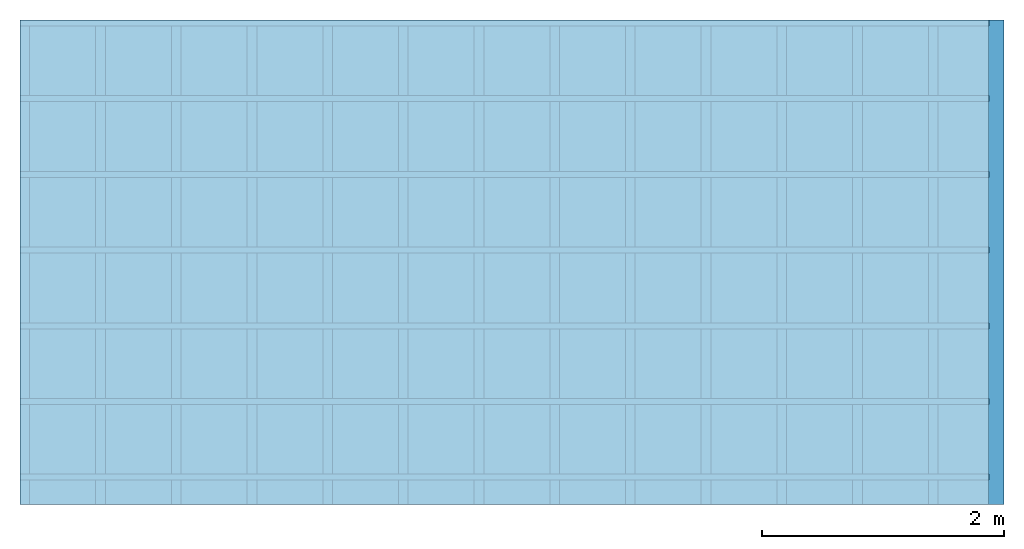
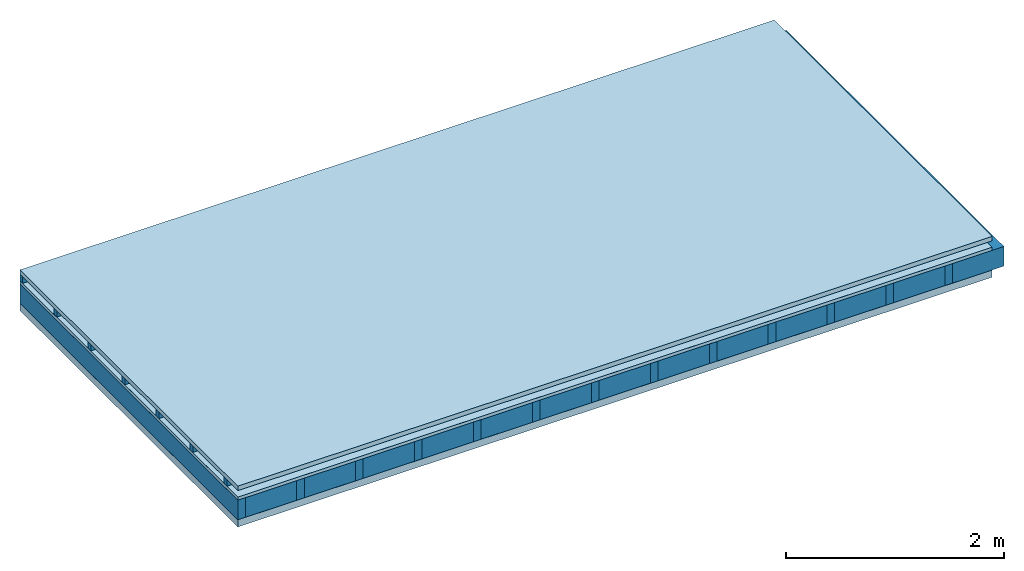
# One storey: 5 plates, 3 members, 1 element without a shape of its own.
"""IFC4 building model written with IfcOpenShell, lengths in metres."""

import ifcopenshell
import ifcopenshell.guid

model = None  # the IFC model being written
_history = None  # IfcOwnerHistory: only IFC2X3 demands one
_inside = {}  # id of a spatial element -> (the spatial element, [elements in it])
_under = {}  # id of a project, library or spatial element -> (it, [spatial elements below it])
_declared = {}  # id of a project -> (the project, [libraries it declares])
_typed = {}  # id of a type object -> (the type object, [elements of that type])
_made_of = {}  # id of a material, layer set ... -> (it, [elements and type objects made of it])


def new_model(schema):
    """Start an empty IFC model of exactly this schema.

    Asked for "IFC4X3", IfcOpenShell would pick the latest addendum, in which some entities
    have other attributes; the version numbers below select the first issue.
    IFC2X3 requires an IfcOwnerHistory on every rooted entity: one is made here for all.
    """
    global model, _history
    if schema == "IFC4X3":
        model = ifcopenshell.file(schema_version=(4, 3, 0, 0))
    else:
        model = ifcopenshell.file(schema=schema)
    _inside.clear()
    _under.clear()
    _declared.clear()
    _typed.clear()
    _made_of.clear()
    _history = None
    if model.schema == "IFC2X3":
        org = make("IfcOrganization", Name="unknown")
        user = make(
            "IfcPersonAndOrganization",
            ThePerson=make("IfcPerson", FamilyName="unknown"),
            TheOrganization=org,
        )
        app = make(
            "IfcApplication",
            ApplicationDeveloper=org,
            Version="unknown",
            ApplicationFullName="unknown",
            ApplicationIdentifier="unknown",
        )
        _history = make(
            "IfcOwnerHistory",
            OwningUser=user,
            OwningApplication=app,
            ChangeAction="ADDED",
            CreationDate=0,
        )
    return model


def make(cls, **values):
    """One entity of the class cls with the attributes given. An attribute that is None is left unset."""
    return model.create_entity(
        cls, **{name: value for name, value in values.items() if value is not None}
    )


def rooted(cls, **values):
    """An entity with a GlobalId (a new one), such as an element, a storey or a relation."""
    return make(cls, GlobalId=ifcopenshell.guid.new(), OwnerHistory=_history, **values)


def si_unit(unit_type, name, prefix=None):
    """IfcSIUnit, for example si_unit("LENGTHUNIT", "METRE", prefix="MILLI")."""
    return make("IfcSIUnit", UnitType=unit_type, Prefix=prefix, Name=name)


def derived_unit(unit_type, elements):
    """IfcDerivedUnit: a product of units, each with its exponent."""
    return make(
        "IfcDerivedUnit",
        Elements=[
            make("IfcDerivedUnitElement", Unit=unit, Exponent=power)
            for unit, power in elements
        ],
        UnitType=unit_type,
    )


def assignment(units):
    """IfcUnitAssignment: the units of a project."""
    return None if units is None else make("IfcUnitAssignment", Units=units)


def point(xyz):
    """IfcCartesianPoint."""
    return None if xyz is None else make("IfcCartesianPoint", Coordinates=xyz)


def direction(xyz):
    """IfcDirection."""
    return None if xyz is None else make("IfcDirection", DirectionRatios=xyz)


def frame(location, z_axis=None, x_axis=None):
    """IfcAxis2Placement3D, a coordinate frame: its origin and axes. An axis left out is left unset."""
    return make(
        "IfcAxis2Placement3D",
        Location=point(location),
        Axis=direction(z_axis),
        RefDirection=direction(x_axis),
    )


def frame_2d(location, x_axis=None):
    """IfcAxis2Placement2D, a coordinate frame in the plane: its origin and x axis."""
    return make(
        "IfcAxis2Placement2D", Location=point(location), RefDirection=direction(x_axis)
    )


def origin():
    """The frame at (0, 0, 0) with its axes left unset."""
    return frame((0.0, 0.0, 0.0))


def origin_with_axes():
    """The frame at (0, 0, 0) with the z axis (0, 0, 1) and the x axis (1, 0, 0) written out."""
    return frame((0.0, 0.0, 0.0), z_axis=(0.0, 0.0, 1.0), x_axis=(1.0, 0.0, 0.0))


def place(relative_to, where):
    """IfcLocalPlacement: puts the frame where relative to a parent placement (None: the world)."""
    return make(
        "IfcLocalPlacement", PlacementRelTo=relative_to, RelativePlacement=where
    )


def context(
    kind, dimensions, precision=None, world=None, true_north=None, identifier=None
):
    """IfcGeometricRepresentationContext, for example the 3D "Model" context."""
    return make(
        "IfcGeometricRepresentationContext",
        ContextIdentifier=identifier,
        ContextType=kind,
        CoordinateSpaceDimension=dimensions,
        Precision=precision,
        WorldCoordinateSystem=world,
        TrueNorth=true_north,
    )


def project(units=None, contexts=None):
    """IfcProject with its units and contexts."""
    return rooted(
        "IfcProject",
        Name="project",
        RepresentationContexts=contexts,
        UnitsInContext=assignment(units),
    )


def spatial(cls, under=None, at=None, **own):
    """A site, building, storey or space (cls), placed at a placement, below another one or the project."""
    s = rooted(cls, ObjectPlacement=at, **own)
    if under is not None:
        _under.setdefault(under.id(), (under, []))[1].append(s)
    return s


def profile(cls, at=None, kind="AREA", **sizes):
    """A parametric profile (cls). Its sizes go by their IFC names, for example OverallWidth=200.0."""
    return make(cls, ProfileType=kind, Position=at, **sizes)


def rectangle(**sizes):
    """IfcRectangleProfileDef."""
    return profile("IfcRectangleProfileDef", **sizes)


def extrude(swept, where, along, depth):
    """IfcExtrudedAreaSolid: the profile swept, set in the frame where, extruded along a direction by depth."""
    return make(
        "IfcExtrudedAreaSolid",
        SweptArea=swept,
        Position=where,
        ExtrudedDirection=direction(along),
        Depth=depth,
    )


def shape(context_of_items, identifier, shape_type, items):
    """IfcShapeRepresentation: the items that make up one representation, for example the "Body"."""
    return make(
        "IfcShapeRepresentation",
        ContextOfItems=context_of_items,
        RepresentationIdentifier=identifier,
        RepresentationType=shape_type,
        Items=items,
    )


def material(Name=None, Category=None):
    """IfcMaterial."""
    return make("IfcMaterial", Name=Name, Category=Category)


def layer(
    of_material, thickness, ventilated=None, Name=None, Category=None, Priority=None
):
    """IfcMaterialLayer: one layer of a wall or slab, of a material (None: an air gap)."""
    return make(
        "IfcMaterialLayer",
        Material=of_material,
        LayerThickness=thickness,
        IsVentilated=ventilated,
        Name=Name,
        Category=Category,
        Priority=Priority,
    )


def layer_set(layers, Name=None):
    """IfcMaterialLayerSet."""
    return make("IfcMaterialLayerSet", MaterialLayers=layers, LayerSetName=Name)


def made_of(thing, what):
    """Note that an element or type object is made of a material, layer set ...; save() writes the relation."""
    if what is not None:
        _made_of.setdefault(what.id(), (what, []))[1].append(thing)
    return thing


def type_object(cls, material=None, **own):
    """A type object (cls), such as IfcWallType, which elements share."""
    return made_of(rooted(cls, **own), material)


def element(
    cls,
    number,
    at=None,
    inside=None,
    cuts=None,
    type_object=None,
    material=None,
    context=None,
    identifier="Body",
    shape_type=None,
    held_by="IfcProductDefinitionShape",
    body=None,
    shapes=None,
    **own,
):
    """One element of the class cls, such as IfcWall. Its Tag is "e" and its number.

    at: its placement. inside: the storey or other place that contains it. cuts: it is an
    opening in that element (IfcRelVoidsElement). A single representation is given by context,
    identifier, shape_type and body (its items); several are given by shapes. held_by: the class
    of the entity that holds the representations. save() writes the other relations.
    """
    e = rooted(cls, Tag="e%d" % number, ObjectPlacement=at, **own)
    if body is not None:
        shapes = [shape(context, identifier, shape_type, body)]
    if shapes is not None:
        e.Representation = make(held_by, Representations=shapes)
    if inside is not None:
        _inside.setdefault(inside.id(), (inside, []))[1].append(e)
    if cuts is not None:
        rooted(
            "IfcRelVoidsElement", RelatingBuildingElement=cuts, RelatedOpeningElement=e
        )
    if type_object is not None:
        _typed.setdefault(type_object.id(), (type_object, []))[1].append(e)
    return made_of(e, material)


def aggregate(whole, parts):
    """IfcRelAggregates: a whole, such as a stair, and the parts it consists of."""
    return rooted("IfcRelAggregates", RelatingObject=whole, RelatedObjects=parts)


def save(model, path):
    """Write the relations noted so far, then the file.

    IfcRelAggregates (storeys below a building ...), IfcRelContainedInSpatialStructure (elements
    in a storey), IfcRelDefinesByType, IfcRelAssociatesMaterial and IfcRelDeclares: one each for
    every whole, place, type object, material and project.
    """
    for whole, parts in _under.values():
        aggregate(whole, parts)
    for where, things in _inside.values():
        rooted(
            "IfcRelContainedInSpatialStructure",
            RelatedElements=things,
            RelatingStructure=where,
        )
    for kind, things in _typed.values():
        rooted("IfcRelDefinesByType", RelatedObjects=things, RelatingType=kind)
    for what, things in _made_of.values():
        rooted("IfcRelAssociatesMaterial", RelatedObjects=things, RelatingMaterial=what)
    for by, libraries in _declared.values():
        rooted("IfcRelDeclares", RelatingContext=by, RelatedDefinitions=libraries)
    model.write(path)


model = new_model("IFC4")

# Units and contexts
plan_context = context("Plan", 3, precision=1e-05, world=origin(), true_north=direction((0.0, 1.0)))
model_context = context("Model", 3, precision=1e-05, world=origin(), true_north=direction((0.0, 1.0)))
ifc_project = project(units=[si_unit("LENGTHUNIT", "METRE"), derived_unit("SOUNDPRESSUREUNIT", [(si_unit("PRESSUREUNIT", "PASCAL", prefix="MICRO"), 0)]), si_unit("ENERGYUNIT", "JOULE", prefix="MEGA"), si_unit("MASSUNIT", "GRAM", prefix="KILO"), derived_unit("THERMALTRANSMITTANCEUNIT", [(si_unit("POWERUNIT", "WATT"), 1), (si_unit("AREAUNIT", "SQUARE_METRE"), -1), (si_unit("THERMODYNAMICTEMPERATUREUNIT", "KELVIN"), -1)]), derived_unit("AREADENSITYUNIT", [(si_unit("MASSUNIT", "GRAM", prefix="KILO"), 1), (si_unit("AREAUNIT", "SQUARE_METRE"), -1)]), derived_unit("USERDEFINED", [(si_unit("ENERGYUNIT", "JOULE", prefix="MEGA"), 1), (si_unit("AREAUNIT", "SQUARE_METRE"), -1)])], contexts=[plan_context, model_context])

# Site, building, storey
site = spatial("IfcSite", under=ifc_project)
building_placement = place(None, origin())
building = spatial("IfcBuilding", under=site, at=building_placement)
storey_placement = place(building_placement, origin())
storey = spatial("IfcBuildingStorey", under=building, at=storey_placement)

# Slab, members, plates
ifc_material_1 = material(Name="Roof tiles", Category="03.015")
ifc_layer_1 = layer(ifc_material_1, 0.05, Name="Roofing")
ifc_layer_2 = layer(None, 0.072, Name="Battens / profiles")
ifc_material_2 = material(Name="Roofing underlay", Category="09.008")
ifc_layer_3 = layer(ifc_material_2, 0.00018, Name="Under the roof")
ifc_material_3 = material(Category="10.009")
ifc_layer_4 = layer(ifc_material_3, 0.035, Name="Sub-floor")
ifc_material_4 = material(Name="of the art")
ifc_layer_5 = layer(ifc_material_4, 0.0, Name="Bond")
ifc_layer_6 = layer(None, 0.22, Name="Supporting structure")
ifc_material_5 = material(Name="Vapor barrier polyethylene (PE)", Category="09.002")
ifc_layer_7 = layer(ifc_material_5, 0.00025, Name="Lower layer 1")
ifc_material_6 = material(Name="Solid timber panel")
ifc_layer_8 = layer(ifc_material_6, 0.08, Name="Lower 2nd layer")
ifc_layer_set = layer_set([ifc_layer_1, ifc_layer_2, ifc_layer_3, ifc_layer_4, ifc_layer_5, ifc_layer_6, ifc_layer_7, ifc_layer_8])
slab_type = type_object("IfcSlabType", Name="E0154", PredefinedType="NOTDEFINED", material=ifc_layer_set)
slab_placement = place(None, frame((0.0, 0.0, 0.0), z_axis=(0.0, 0.0, -1.0), x_axis=(1.0, 0.0, 0.0)))
slab = element("IfcSlab", 1, at=slab_placement, inside=storey, type_object=slab_type, material=ifc_layer_set, Name="Slab #1")
ifc_material_7 = material()
member_1_placement = place(slab_placement, origin())
member_1 = element("IfcMember", 2, at=member_1_placement, material=ifc_material_7, Name="Battens / profiles", context=plan_context, shape_type="SweptSolid", body=[
    extrude(rectangle(XDim=0.05, YDim=0.072, at=frame_2d((0.025, 0.036), x_axis=(1.0, 0.0))), frame((0.0, 0.0, 0.05), z_axis=(1.0, 0.0, 0.0), x_axis=(0.0, 1.0, 0.0)), (0.0, 0.0, 1.0), 8.0),
    extrude(rectangle(XDim=0.05, YDim=0.072, at=frame_2d((0.025, 0.036), x_axis=(1.0, 0.0))), frame((0.0, 0.625, 0.05), z_axis=(1.0, 0.0, 0.0), x_axis=(0.0, 1.0, 0.0)), (0.0, 0.0, 1.0), 8.0),
    extrude(rectangle(XDim=0.05, YDim=0.072, at=frame_2d((0.025, 0.036), x_axis=(1.0, 0.0))), frame((0.0, 1.25, 0.05), z_axis=(1.0, 0.0, 0.0), x_axis=(0.0, 1.0, 0.0)), (0.0, 0.0, 1.0), 8.0),
    extrude(rectangle(XDim=0.05, YDim=0.072, at=frame_2d((0.025, 0.036), x_axis=(1.0, 0.0))), frame((0.0, 1.875, 0.05), z_axis=(1.0, 0.0, 0.0), x_axis=(0.0, 1.0, 0.0)), (0.0, 0.0, 1.0), 8.0),
    extrude(rectangle(XDim=0.05, YDim=0.072, at=frame_2d((0.025, 0.036), x_axis=(1.0, 0.0))), frame((0.0, 2.5, 0.05), z_axis=(1.0, 0.0, 0.0), x_axis=(0.0, 1.0, 0.0)), (0.0, 0.0, 1.0), 8.0),
    extrude(rectangle(XDim=0.05, YDim=0.072, at=frame_2d((0.025, 0.036), x_axis=(1.0, 0.0))), frame((0.0, 3.125, 0.05), z_axis=(1.0, 0.0, 0.0), x_axis=(0.0, 1.0, 0.0)), (0.0, 0.0, 1.0), 8.0),
    extrude(rectangle(XDim=0.05, YDim=0.072, at=frame_2d((0.025, 0.036), x_axis=(1.0, 0.0))), frame((0.0, 3.75, 0.05), z_axis=(1.0, 0.0, 0.0), x_axis=(0.0, 1.0, 0.0)), (0.0, 0.0, 1.0), 8.0),
])
ifc_material_8 = material()
member_2_placement = place(slab_placement, origin())
member_2 = element("IfcMember", 3, at=member_2_placement, material=ifc_material_8, Name="Supporting structure", context=plan_context, shape_type="SweptSolid", body=[
    extrude(rectangle(XDim=0.08, YDim=0.22, at=frame_2d((0.04, 0.11), x_axis=(1.0, 0.0))), frame((0.0, 4.0, 0.15718), z_axis=(0.0, -1.0, 0.0), x_axis=(1.0, 0.0, 0.0)), (0.0, 0.0, 1.0), 4.0),
    extrude(rectangle(XDim=0.08, YDim=0.22, at=frame_2d((0.04, 0.11), x_axis=(1.0, 0.0))), frame((0.625, 4.0, 0.15718), z_axis=(0.0, -1.0, 0.0), x_axis=(1.0, 0.0, 0.0)), (0.0, 0.0, 1.0), 4.0),
    extrude(rectangle(XDim=0.08, YDim=0.22, at=frame_2d((0.04, 0.11), x_axis=(1.0, 0.0))), frame((1.25, 4.0, 0.15718), z_axis=(0.0, -1.0, 0.0), x_axis=(1.0, 0.0, 0.0)), (0.0, 0.0, 1.0), 4.0),
    extrude(rectangle(XDim=0.08, YDim=0.22, at=frame_2d((0.04, 0.11), x_axis=(1.0, 0.0))), frame((1.875, 4.0, 0.15718), z_axis=(0.0, -1.0, 0.0), x_axis=(1.0, 0.0, 0.0)), (0.0, 0.0, 1.0), 4.0),
    extrude(rectangle(XDim=0.08, YDim=0.22, at=frame_2d((0.04, 0.11), x_axis=(1.0, 0.0))), frame((2.5, 4.0, 0.15718), z_axis=(0.0, -1.0, 0.0), x_axis=(1.0, 0.0, 0.0)), (0.0, 0.0, 1.0), 4.0),
    extrude(rectangle(XDim=0.08, YDim=0.22, at=frame_2d((0.04, 0.11), x_axis=(1.0, 0.0))), frame((3.125, 4.0, 0.15718), z_axis=(0.0, -1.0, 0.0), x_axis=(1.0, 0.0, 0.0)), (0.0, 0.0, 1.0), 4.0),
    extrude(rectangle(XDim=0.08, YDim=0.22, at=frame_2d((0.04, 0.11), x_axis=(1.0, 0.0))), frame((3.75, 4.0, 0.15718), z_axis=(0.0, -1.0, 0.0), x_axis=(1.0, 0.0, 0.0)), (0.0, 0.0, 1.0), 4.0),
    extrude(rectangle(XDim=0.08, YDim=0.22, at=frame_2d((0.04, 0.11), x_axis=(1.0, 0.0))), frame((4.375, 4.0, 0.15718), z_axis=(0.0, -1.0, 0.0), x_axis=(1.0, 0.0, 0.0)), (0.0, 0.0, 1.0), 4.0),
    extrude(rectangle(XDim=0.08, YDim=0.22, at=frame_2d((0.04, 0.11), x_axis=(1.0, 0.0))), frame((5.0, 4.0, 0.15718), z_axis=(0.0, -1.0, 0.0), x_axis=(1.0, 0.0, 0.0)), (0.0, 0.0, 1.0), 4.0),
    extrude(rectangle(XDim=0.08, YDim=0.22, at=frame_2d((0.04, 0.11), x_axis=(1.0, 0.0))), frame((5.625, 4.0, 0.15718), z_axis=(0.0, -1.0, 0.0), x_axis=(1.0, 0.0, 0.0)), (0.0, 0.0, 1.0), 4.0),
    extrude(rectangle(XDim=0.08, YDim=0.22, at=frame_2d((0.04, 0.11), x_axis=(1.0, 0.0))), frame((6.25, 4.0, 0.15718), z_axis=(0.0, -1.0, 0.0), x_axis=(1.0, 0.0, 0.0)), (0.0, 0.0, 1.0), 4.0),
    extrude(rectangle(XDim=0.08, YDim=0.22, at=frame_2d((0.04, 0.11), x_axis=(1.0, 0.0))), frame((6.875, 4.0, 0.15718), z_axis=(0.0, -1.0, 0.0), x_axis=(1.0, 0.0, 0.0)), (0.0, 0.0, 1.0), 4.0),
    extrude(rectangle(XDim=0.08, YDim=0.22, at=frame_2d((0.04, 0.11), x_axis=(1.0, 0.0))), frame((7.5, 4.0, 0.15718), z_axis=(0.0, -1.0, 0.0), x_axis=(1.0, 0.0, 0.0)), (0.0, 0.0, 1.0), 4.0),
])
ifc_material_9 = material(Name="Mineral wool")
member_3_placement = place(slab_placement, origin())
member_3 = element("IfcMember", 4, at=member_3_placement, material=ifc_material_9, Name="Cavity", context=plan_context, shape_type="SweptSolid", body=[
    extrude(rectangle(XDim=0.545, YDim=0.22, at=frame_2d((0.2725, 0.11), x_axis=(1.0, 0.0))), frame((0.08, 4.0, 0.15718), z_axis=(0.0, -1.0, 0.0), x_axis=(1.0, 0.0, 0.0)), (0.0, 0.0, 1.0), 4.0),
    extrude(rectangle(XDim=0.545, YDim=0.22, at=frame_2d((0.2725, 0.11), x_axis=(1.0, 0.0))), frame((0.705, 4.0, 0.15718), z_axis=(0.0, -1.0, 0.0), x_axis=(1.0, 0.0, 0.0)), (0.0, 0.0, 1.0), 4.0),
    extrude(rectangle(XDim=0.545, YDim=0.22, at=frame_2d((0.2725, 0.11), x_axis=(1.0, 0.0))), frame((1.33, 4.0, 0.15718), z_axis=(0.0, -1.0, 0.0), x_axis=(1.0, 0.0, 0.0)), (0.0, 0.0, 1.0), 4.0),
    extrude(rectangle(XDim=0.545, YDim=0.22, at=frame_2d((0.2725, 0.11), x_axis=(1.0, 0.0))), frame((1.955, 4.0, 0.15718), z_axis=(0.0, -1.0, 0.0), x_axis=(1.0, 0.0, 0.0)), (0.0, 0.0, 1.0), 4.0),
    extrude(rectangle(XDim=0.545, YDim=0.22, at=frame_2d((0.2725, 0.11), x_axis=(1.0, 0.0))), frame((2.58, 4.0, 0.15718), z_axis=(0.0, -1.0, 0.0), x_axis=(1.0, 0.0, 0.0)), (0.0, 0.0, 1.0), 4.0),
    extrude(rectangle(XDim=0.545, YDim=0.22, at=frame_2d((0.2725, 0.11), x_axis=(1.0, 0.0))), frame((3.205, 4.0, 0.15718), z_axis=(0.0, -1.0, 0.0), x_axis=(1.0, 0.0, 0.0)), (0.0, 0.0, 1.0), 4.0),
    extrude(rectangle(XDim=0.545, YDim=0.22, at=frame_2d((0.2725, 0.11), x_axis=(1.0, 0.0))), frame((3.83, 4.0, 0.15718), z_axis=(0.0, -1.0, 0.0), x_axis=(1.0, 0.0, 0.0)), (0.0, 0.0, 1.0), 4.0),
    extrude(rectangle(XDim=0.545, YDim=0.22, at=frame_2d((0.2725, 0.11), x_axis=(1.0, 0.0))), frame((4.455, 4.0, 0.15718), z_axis=(0.0, -1.0, 0.0), x_axis=(1.0, 0.0, 0.0)), (0.0, 0.0, 1.0), 4.0),
    extrude(rectangle(XDim=0.545, YDim=0.22, at=frame_2d((0.2725, 0.11), x_axis=(1.0, 0.0))), frame((5.08, 4.0, 0.15718), z_axis=(0.0, -1.0, 0.0), x_axis=(1.0, 0.0, 0.0)), (0.0, 0.0, 1.0), 4.0),
    extrude(rectangle(XDim=0.545, YDim=0.22, at=frame_2d((0.2725, 0.11), x_axis=(1.0, 0.0))), frame((5.705, 4.0, 0.15718), z_axis=(0.0, -1.0, 0.0), x_axis=(1.0, 0.0, 0.0)), (0.0, 0.0, 1.0), 4.0),
    extrude(rectangle(XDim=0.545, YDim=0.22, at=frame_2d((0.2725, 0.11), x_axis=(1.0, 0.0))), frame((6.33, 4.0, 0.15718), z_axis=(0.0, -1.0, 0.0), x_axis=(1.0, 0.0, 0.0)), (0.0, 0.0, 1.0), 4.0),
    extrude(rectangle(XDim=0.545, YDim=0.22, at=frame_2d((0.2725, 0.11), x_axis=(1.0, 0.0))), frame((6.955, 4.0, 0.15718), z_axis=(0.0, -1.0, 0.0), x_axis=(1.0, 0.0, 0.0)), (0.0, 0.0, 1.0), 4.0),
    extrude(rectangle(XDim=0.545, YDim=0.22, at=frame_2d((0.2725, 0.11), x_axis=(1.0, 0.0))), frame((7.58, 4.0, 0.15718), z_axis=(0.0, -1.0, 0.0), x_axis=(1.0, 0.0, 0.0)), (0.0, 0.0, 1.0), 4.0),
])
plate_1_placement = place(slab_placement, origin())
plate_1 = element("IfcPlate", 5, at=plate_1_placement, material=ifc_material_1, Name="Roofing", context=plan_context, shape_type="SweptSolid", body=[
    extrude(rectangle(XDim=8.0, YDim=4.0, at=frame_2d((4.0, 2.0), x_axis=(1.0, 0.0))), origin_with_axes(), (0.0, 0.0, 1.0), 0.05),
])
plate_2_placement = place(slab_placement, origin())
plate_2 = element("IfcPlate", 6, at=plate_2_placement, material=ifc_material_2, Name="Under the roof", context=plan_context, shape_type="SweptSolid", body=[
    extrude(rectangle(XDim=8.0, YDim=4.0, at=frame_2d((4.0, 2.0), x_axis=(1.0, 0.0))), frame((0.0, 0.0, 0.122), z_axis=(0.0, 0.0, 1.0), x_axis=(1.0, 0.0, 0.0)), (0.0, 0.0, 1.0), 0.00018),
])
plate_3_placement = place(slab_placement, origin())
plate_3 = element("IfcPlate", 7, at=plate_3_placement, material=ifc_material_3, Name="Sub-floor", context=plan_context, shape_type="SweptSolid", body=[
    extrude(rectangle(XDim=8.0, YDim=4.0, at=frame_2d((4.0, 2.0), x_axis=(1.0, 0.0))), frame((0.0, 0.0, 0.12218), z_axis=(0.0, 0.0, 1.0), x_axis=(1.0, 0.0, 0.0)), (0.0, 0.0, 1.0), 0.035),
])
plate_4_placement = place(slab_placement, origin())
plate_4 = element("IfcPlate", 8, at=plate_4_placement, material=ifc_material_5, Name="Lower layer 1", context=plan_context, shape_type="SweptSolid", body=[
    extrude(rectangle(XDim=8.0, YDim=4.0, at=frame_2d((4.0, 2.0), x_axis=(1.0, 0.0))), frame((0.0, 0.0, 0.37718), z_axis=(0.0, 0.0, 1.0), x_axis=(1.0, 0.0, 0.0)), (0.0, 0.0, 1.0), 0.00025),
])
plate_5_placement = place(slab_placement, origin())
plate_5 = element("IfcPlate", 9, at=plate_5_placement, material=ifc_material_6, Name="Lower 2nd layer", context=plan_context, shape_type="SweptSolid", body=[
    extrude(rectangle(XDim=8.0, YDim=4.0, at=frame_2d((4.0, 2.0), x_axis=(1.0, 0.0))), frame((0.0, 0.0, 0.37743), z_axis=(0.0, 0.0, 1.0), x_axis=(1.0, 0.0, 0.0)), (0.0, 0.0, 1.0), 0.08),
])
aggregate(slab, [plate_1, member_1, plate_2, plate_3, member_2, member_3, plate_4, plate_5])

save(model, "model.ifc")
